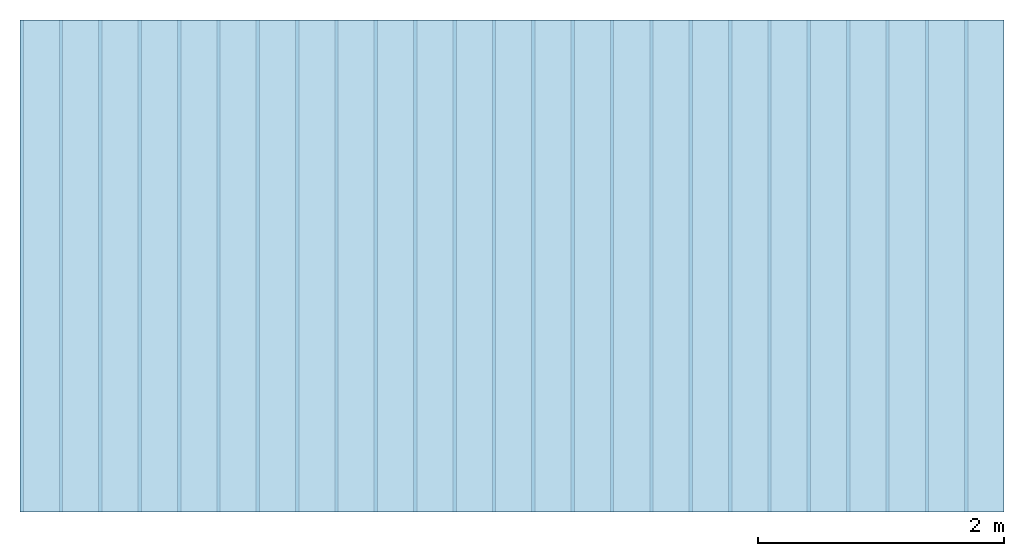
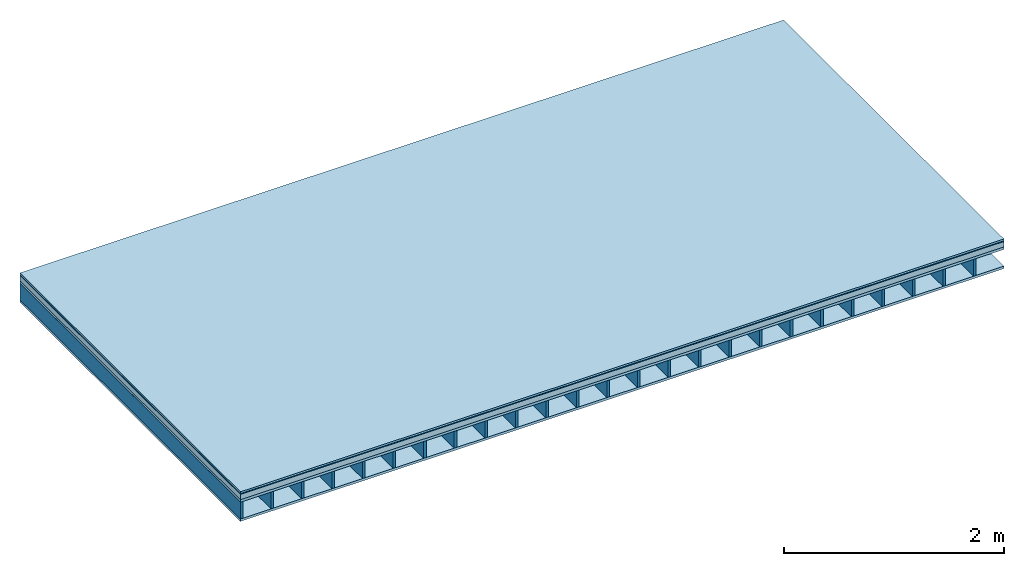
# One storey: 5 plates, 1 member, 1 element without a shape of its own.
"""IFC4 building model written with IfcOpenShell, lengths in metres."""

from ifc_helpers import new_model, si_unit, derived_unit, direction, frame, frame_2d, origin, origin_with_axes, place, context, project, spatial, rectangle, extrude, material, layer, layer_set, type_object, element, aggregate, save


model = new_model("IFC4")

# Units and contexts
plan_context = context("Plan", 3, precision=1e-05, world=origin(), true_north=direction((0.0, 1.0)))
model_context = context("Model", 3, precision=1e-05, world=origin(), true_north=direction((0.0, 1.0)))
ifc_project = project(units=[si_unit("LENGTHUNIT", "METRE"), derived_unit("SOUNDPRESSUREUNIT", [(si_unit("PRESSUREUNIT", "PASCAL", prefix="MICRO"), 0)]), si_unit("ENERGYUNIT", "JOULE", prefix="MEGA"), si_unit("MASSUNIT", "GRAM", prefix="KILO"), derived_unit("THERMALTRANSMITTANCEUNIT", [(si_unit("POWERUNIT", "WATT"), 1), (si_unit("AREAUNIT", "SQUARE_METRE"), -1), (si_unit("THERMODYNAMICTEMPERATUREUNIT", "KELVIN"), -1)]), derived_unit("AREADENSITYUNIT", [(si_unit("MASSUNIT", "GRAM", prefix="KILO"), 1), (si_unit("AREAUNIT", "SQUARE_METRE"), -1)]), derived_unit("USERDEFINED", [(si_unit("ENERGYUNIT", "JOULE", prefix="MEGA"), 1), (si_unit("AREAUNIT", "SQUARE_METRE"), -1)])], contexts=[plan_context, model_context])

# Site, building, storey
site = spatial("IfcSite", under=ifc_project)
building_placement = place(None, origin())
building = spatial("IfcBuilding", under=site, at=building_placement)
storey_placement = place(building_placement, origin())
storey = spatial("IfcBuildingStorey", under=building, at=storey_placement)

# Slab, member, plates
ifc_material_1 = material(Category="03.007")
ifc_layer_1 = layer(ifc_material_1, 0.02, Name="On-material")
ifc_material_2 = material(Name="base", Category="10.009")
ifc_layer_2 = layer(ifc_material_2, 0.008, Name="Impact sound insulation")
ifc_material_3 = material(Name="with broken")
ifc_layer_3 = layer(ifc_material_3, 0.06, Name="on Supporting structure")
ifc_material_4 = material(Name="3-layer board Spruce Nova Top", Category="07.001")
ifc_layer_4 = layer(ifc_material_4, 0.027, Name="Sub-floor")
ifc_material_5 = material(Name="Rigid, of the art")
ifc_layer_5 = layer(ifc_material_5, 0.0, Name="Bond")
ifc_layer_6 = layer(None, 0.186, Name="Supporting structure")
ifc_layer_7 = layer(ifc_material_5, 0.0, Name="Bond")
ifc_layer_8 = layer(ifc_material_4, 0.027, Name="Lower layer 1")
ifc_layer_set = layer_set([ifc_layer_1, ifc_layer_2, ifc_layer_3, ifc_layer_4, ifc_layer_5, ifc_layer_6, ifc_layer_7, ifc_layer_8])
slab_type = type_object("IfcSlabType", Name="A0014", PredefinedType="NOTDEFINED", material=ifc_layer_set)
slab_placement = place(None, frame((0.0, 0.0, 0.0), z_axis=(0.0, 0.0, -1.0), x_axis=(1.0, 0.0, 0.0)))
slab = element("IfcSlab", 1, at=slab_placement, inside=storey, type_object=slab_type, material=ifc_layer_set, Name="Slab #1")
ifc_material_6 = material()
member_placement = place(slab_placement, origin())
member = element("IfcMember", 2, at=member_placement, material=ifc_material_6, Name="Supporting structure", context=plan_context, shape_type="SweptSolid", body=[
    extrude(rectangle(XDim=0.027, YDim=0.186, at=frame_2d((0.0135, 0.093), x_axis=(1.0, 0.0))), frame((0.0, 4.0, 0.115), z_axis=(0.0, -1.0, 0.0), x_axis=(1.0, 0.0, 0.0)), (0.0, 0.0, 1.0), 4.0),
    extrude(rectangle(XDim=0.027, YDim=0.186, at=frame_2d((0.0135, 0.093), x_axis=(1.0, 0.0))), frame((0.32, 4.0, 0.115), z_axis=(0.0, -1.0, 0.0), x_axis=(1.0, 0.0, 0.0)), (0.0, 0.0, 1.0), 4.0),
    extrude(rectangle(XDim=0.027, YDim=0.186, at=frame_2d((0.0135, 0.093), x_axis=(1.0, 0.0))), frame((0.64, 4.0, 0.115), z_axis=(0.0, -1.0, 0.0), x_axis=(1.0, 0.0, 0.0)), (0.0, 0.0, 1.0), 4.0),
    extrude(rectangle(XDim=0.027, YDim=0.186, at=frame_2d((0.0135, 0.093), x_axis=(1.0, 0.0))), frame((0.96, 4.0, 0.115), z_axis=(0.0, -1.0, 0.0), x_axis=(1.0, 0.0, 0.0)), (0.0, 0.0, 1.0), 4.0),
    extrude(rectangle(XDim=0.027, YDim=0.186, at=frame_2d((0.0135, 0.093), x_axis=(1.0, 0.0))), frame((1.28, 4.0, 0.115), z_axis=(0.0, -1.0, 0.0), x_axis=(1.0, 0.0, 0.0)), (0.0, 0.0, 1.0), 4.0),
    extrude(rectangle(XDim=0.027, YDim=0.186, at=frame_2d((0.0135, 0.093), x_axis=(1.0, 0.0))), frame((1.6, 4.0, 0.115), z_axis=(0.0, -1.0, 0.0), x_axis=(1.0, 0.0, 0.0)), (0.0, 0.0, 1.0), 4.0),
    extrude(rectangle(XDim=0.027, YDim=0.186, at=frame_2d((0.0135, 0.093), x_axis=(1.0, 0.0))), frame((1.92, 4.0, 0.115), z_axis=(0.0, -1.0, 0.0), x_axis=(1.0, 0.0, 0.0)), (0.0, 0.0, 1.0), 4.0),
    extrude(rectangle(XDim=0.027, YDim=0.186, at=frame_2d((0.0135, 0.093), x_axis=(1.0, 0.0))), frame((2.24, 4.0, 0.115), z_axis=(0.0, -1.0, 0.0), x_axis=(1.0, 0.0, 0.0)), (0.0, 0.0, 1.0), 4.0),
    extrude(rectangle(XDim=0.027, YDim=0.186, at=frame_2d((0.0135, 0.093), x_axis=(1.0, 0.0))), frame((2.56, 4.0, 0.115), z_axis=(0.0, -1.0, 0.0), x_axis=(1.0, 0.0, 0.0)), (0.0, 0.0, 1.0), 4.0),
    extrude(rectangle(XDim=0.027, YDim=0.186, at=frame_2d((0.0135, 0.093), x_axis=(1.0, 0.0))), frame((2.88, 4.0, 0.115), z_axis=(0.0, -1.0, 0.0), x_axis=(1.0, 0.0, 0.0)), (0.0, 0.0, 1.0), 4.0),
    extrude(rectangle(XDim=0.027, YDim=0.186, at=frame_2d((0.0135, 0.093), x_axis=(1.0, 0.0))), frame((3.2, 4.0, 0.115), z_axis=(0.0, -1.0, 0.0), x_axis=(1.0, 0.0, 0.0)), (0.0, 0.0, 1.0), 4.0),
    extrude(rectangle(XDim=0.027, YDim=0.186, at=frame_2d((0.0135, 0.093), x_axis=(1.0, 0.0))), frame((3.52, 4.0, 0.115), z_axis=(0.0, -1.0, 0.0), x_axis=(1.0, 0.0, 0.0)), (0.0, 0.0, 1.0), 4.0),
    extrude(rectangle(XDim=0.027, YDim=0.186, at=frame_2d((0.0135, 0.093), x_axis=(1.0, 0.0))), frame((3.84, 4.0, 0.115), z_axis=(0.0, -1.0, 0.0), x_axis=(1.0, 0.0, 0.0)), (0.0, 0.0, 1.0), 4.0),
    extrude(rectangle(XDim=0.027, YDim=0.186, at=frame_2d((0.0135, 0.093), x_axis=(1.0, 0.0))), frame((4.16, 4.0, 0.115), z_axis=(0.0, -1.0, 0.0), x_axis=(1.0, 0.0, 0.0)), (0.0, 0.0, 1.0), 4.0),
    extrude(rectangle(XDim=0.027, YDim=0.186, at=frame_2d((0.0135, 0.093), x_axis=(1.0, 0.0))), frame((4.48, 4.0, 0.115), z_axis=(0.0, -1.0, 0.0), x_axis=(1.0, 0.0, 0.0)), (0.0, 0.0, 1.0), 4.0),
    extrude(rectangle(XDim=0.027, YDim=0.186, at=frame_2d((0.0135, 0.093), x_axis=(1.0, 0.0))), frame((4.8, 4.0, 0.115), z_axis=(0.0, -1.0, 0.0), x_axis=(1.0, 0.0, 0.0)), (0.0, 0.0, 1.0), 4.0),
    extrude(rectangle(XDim=0.027, YDim=0.186, at=frame_2d((0.0135, 0.093), x_axis=(1.0, 0.0))), frame((5.12, 4.0, 0.115), z_axis=(0.0, -1.0, 0.0), x_axis=(1.0, 0.0, 0.0)), (0.0, 0.0, 1.0), 4.0),
    extrude(rectangle(XDim=0.027, YDim=0.186, at=frame_2d((0.0135, 0.093), x_axis=(1.0, 0.0))), frame((5.44, 4.0, 0.115), z_axis=(0.0, -1.0, 0.0), x_axis=(1.0, 0.0, 0.0)), (0.0, 0.0, 1.0), 4.0),
    extrude(rectangle(XDim=0.027, YDim=0.186, at=frame_2d((0.0135, 0.093), x_axis=(1.0, 0.0))), frame((5.76, 4.0, 0.115), z_axis=(0.0, -1.0, 0.0), x_axis=(1.0, 0.0, 0.0)), (0.0, 0.0, 1.0), 4.0),
    extrude(rectangle(XDim=0.027, YDim=0.186, at=frame_2d((0.0135, 0.093), x_axis=(1.0, 0.0))), frame((6.08, 4.0, 0.115), z_axis=(0.0, -1.0, 0.0), x_axis=(1.0, 0.0, 0.0)), (0.0, 0.0, 1.0), 4.0),
    extrude(rectangle(XDim=0.027, YDim=0.186, at=frame_2d((0.0135, 0.093), x_axis=(1.0, 0.0))), frame((6.4, 4.0, 0.115), z_axis=(0.0, -1.0, 0.0), x_axis=(1.0, 0.0, 0.0)), (0.0, 0.0, 1.0), 4.0),
    extrude(rectangle(XDim=0.027, YDim=0.186, at=frame_2d((0.0135, 0.093), x_axis=(1.0, 0.0))), frame((6.72, 4.0, 0.115), z_axis=(0.0, -1.0, 0.0), x_axis=(1.0, 0.0, 0.0)), (0.0, 0.0, 1.0), 4.0),
    extrude(rectangle(XDim=0.027, YDim=0.186, at=frame_2d((0.0135, 0.093), x_axis=(1.0, 0.0))), frame((7.04, 4.0, 0.115), z_axis=(0.0, -1.0, 0.0), x_axis=(1.0, 0.0, 0.0)), (0.0, 0.0, 1.0), 4.0),
    extrude(rectangle(XDim=0.027, YDim=0.186, at=frame_2d((0.0135, 0.093), x_axis=(1.0, 0.0))), frame((7.36, 4.0, 0.115), z_axis=(0.0, -1.0, 0.0), x_axis=(1.0, 0.0, 0.0)), (0.0, 0.0, 1.0), 4.0),
    extrude(rectangle(XDim=0.027, YDim=0.186, at=frame_2d((0.0135, 0.093), x_axis=(1.0, 0.0))), frame((7.68, 4.0, 0.115), z_axis=(0.0, -1.0, 0.0), x_axis=(1.0, 0.0, 0.0)), (0.0, 0.0, 1.0), 4.0),
])
plate_1_placement = place(slab_placement, origin())
plate_1 = element("IfcPlate", 3, at=plate_1_placement, material=ifc_material_1, Name="On-material", context=plan_context, shape_type="SweptSolid", body=[
    extrude(rectangle(XDim=8.0, YDim=4.0, at=frame_2d((4.0, 2.0), x_axis=(1.0, 0.0))), origin_with_axes(), (0.0, 0.0, 1.0), 0.02),
])
plate_2_placement = place(slab_placement, origin())
plate_2 = element("IfcPlate", 4, at=plate_2_placement, material=ifc_material_2, Name="Impact sound insulation", context=plan_context, shape_type="SweptSolid", body=[
    extrude(rectangle(XDim=8.0, YDim=4.0, at=frame_2d((4.0, 2.0), x_axis=(1.0, 0.0))), frame((0.0, 0.0, 0.02), z_axis=(0.0, 0.0, 1.0), x_axis=(1.0, 0.0, 0.0)), (0.0, 0.0, 1.0), 0.008),
])
plate_3_placement = place(slab_placement, origin())
plate_3 = element("IfcPlate", 5, at=plate_3_placement, material=ifc_material_3, Name="on Supporting structure", context=plan_context, shape_type="SweptSolid", body=[
    extrude(rectangle(XDim=8.0, YDim=4.0, at=frame_2d((4.0, 2.0), x_axis=(1.0, 0.0))), frame((0.0, 0.0, 0.028), z_axis=(0.0, 0.0, 1.0), x_axis=(1.0, 0.0, 0.0)), (0.0, 0.0, 1.0), 0.06),
])
plate_4_placement = place(slab_placement, origin())
plate_4 = element("IfcPlate", 6, at=plate_4_placement, material=ifc_material_4, Name="Sub-floor", context=plan_context, shape_type="SweptSolid", body=[
    extrude(rectangle(XDim=8.0, YDim=4.0, at=frame_2d((4.0, 2.0), x_axis=(1.0, 0.0))), frame((0.0, 0.0, 0.088), z_axis=(0.0, 0.0, 1.0), x_axis=(1.0, 0.0, 0.0)), (0.0, 0.0, 1.0), 0.027),
])
plate_5_placement = place(slab_placement, origin())
plate_5 = element("IfcPlate", 7, at=plate_5_placement, material=ifc_material_4, Name="Lower layer 1", context=plan_context, shape_type="SweptSolid", body=[
    extrude(rectangle(XDim=8.0, YDim=4.0, at=frame_2d((4.0, 2.0), x_axis=(1.0, 0.0))), frame((0.0, 0.0, 0.301), z_axis=(0.0, 0.0, 1.0), x_axis=(1.0, 0.0, 0.0)), (0.0, 0.0, 1.0), 0.027),
])
aggregate(slab, [plate_1, plate_2, plate_3, plate_4, member, plate_5])

save(model, "model.ifc")
